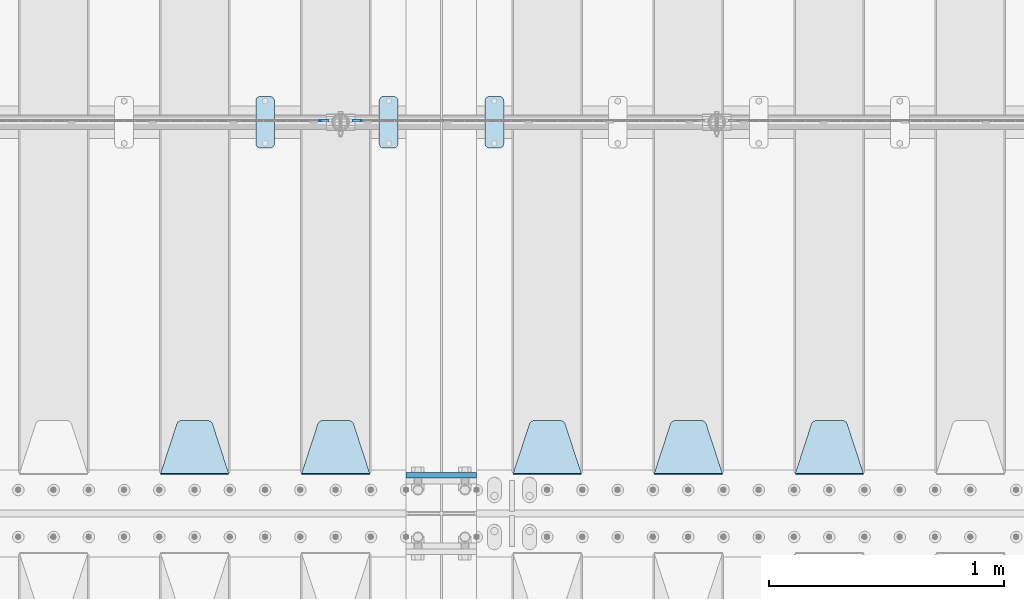
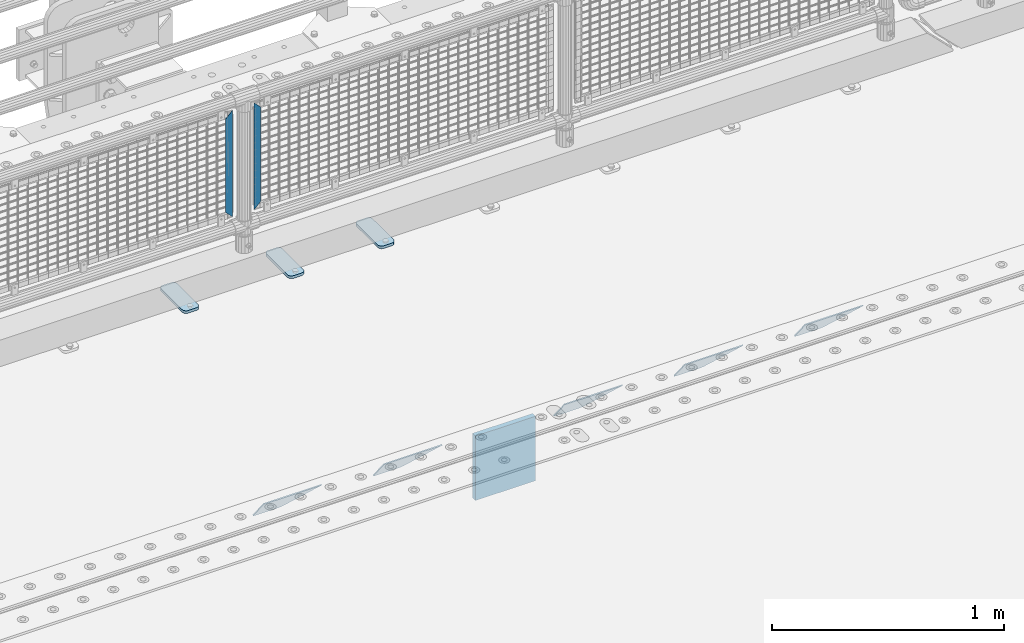
# One storey, part 184 of 208: 11 plates.
"""IFC2X3 building model written with IfcOpenShell, lengths in millimetres."""

import ifcopenshell
import ifcopenshell.guid

model = None  # the IFC model being written
_history = None  # IfcOwnerHistory: only IFC2X3 demands one
_inside = {}  # id of a spatial element -> (the spatial element, [elements in it])
_under = {}  # id of a project, library or spatial element -> (it, [spatial elements below it])
_declared = {}  # id of a project -> (the project, [libraries it declares])
_typed = {}  # id of a type object -> (the type object, [elements of that type])
_made_of = {}  # id of a material, layer set ... -> (it, [elements and type objects made of it])


def new_model(schema):
    """Start an empty IFC model of exactly this schema.

    Asked for "IFC4X3", IfcOpenShell would pick the latest addendum, in which some entities
    have other attributes; the version numbers below select the first issue.
    IFC2X3 requires an IfcOwnerHistory on every rooted entity: one is made here for all.
    """
    global model, _history
    if schema == "IFC4X3":
        model = ifcopenshell.file(schema_version=(4, 3, 0, 0))
    else:
        model = ifcopenshell.file(schema=schema)
    _inside.clear()
    _under.clear()
    _declared.clear()
    _typed.clear()
    _made_of.clear()
    _history = None
    if model.schema == "IFC2X3":
        org = make("IfcOrganization", Name="unknown")
        user = make(
            "IfcPersonAndOrganization",
            ThePerson=make("IfcPerson", FamilyName="unknown"),
            TheOrganization=org,
        )
        app = make(
            "IfcApplication",
            ApplicationDeveloper=org,
            Version="unknown",
            ApplicationFullName="unknown",
            ApplicationIdentifier="unknown",
        )
        _history = make(
            "IfcOwnerHistory",
            OwningUser=user,
            OwningApplication=app,
            ChangeAction="ADDED",
            CreationDate=0,
        )
    return model


def make(cls, **values):
    """One entity of the class cls with the attributes given. An attribute that is None is left unset."""
    return model.create_entity(
        cls, **{name: value for name, value in values.items() if value is not None}
    )


def rooted(cls, **values):
    """An entity with a GlobalId (a new one), such as an element, a storey or a relation."""
    return make(cls, GlobalId=ifcopenshell.guid.new(), OwnerHistory=_history, **values)


def si_unit(unit_type, name, prefix=None):
    """IfcSIUnit, for example si_unit("LENGTHUNIT", "METRE", prefix="MILLI")."""
    return make("IfcSIUnit", UnitType=unit_type, Prefix=prefix, Name=name)


def assignment(units):
    """IfcUnitAssignment: the units of a project."""
    return None if units is None else make("IfcUnitAssignment", Units=units)


def point(xyz):
    """IfcCartesianPoint."""
    return None if xyz is None else make("IfcCartesianPoint", Coordinates=xyz)


def direction(xyz):
    """IfcDirection."""
    return None if xyz is None else make("IfcDirection", DirectionRatios=xyz)


def frame(location, z_axis=None, x_axis=None):
    """IfcAxis2Placement3D, a coordinate frame: its origin and axes. An axis left out is left unset."""
    return make(
        "IfcAxis2Placement3D",
        Location=point(location),
        Axis=direction(z_axis),
        RefDirection=direction(x_axis),
    )


def origin_with_axes():
    """The frame at (0, 0, 0) with the z axis (0, 0, 1) and the x axis (1, 0, 0) written out."""
    return frame((0.0, 0.0, 0.0), z_axis=(0.0, 0.0, 1.0), x_axis=(1.0, 0.0, 0.0))


def place(relative_to, where):
    """IfcLocalPlacement: puts the frame where relative to a parent placement (None: the world)."""
    return make(
        "IfcLocalPlacement", PlacementRelTo=relative_to, RelativePlacement=where
    )


def context(
    kind, dimensions, precision=None, world=None, true_north=None, identifier=None
):
    """IfcGeometricRepresentationContext, for example the 3D "Model" context."""
    return make(
        "IfcGeometricRepresentationContext",
        ContextIdentifier=identifier,
        ContextType=kind,
        CoordinateSpaceDimension=dimensions,
        Precision=precision,
        WorldCoordinateSystem=world,
        TrueNorth=true_north,
    )


def subcontext(parent, identifier, kind, view, scale=None):
    """IfcGeometricRepresentationSubContext, for example "Body" below "Model"."""
    return make(
        "IfcGeometricRepresentationSubContext",
        ContextIdentifier=identifier,
        ContextType=kind,
        ParentContext=parent,
        TargetScale=scale,
        TargetView=view,
    )


def project(units=None, contexts=None):
    """IfcProject with its units and contexts."""
    return rooted(
        "IfcProject",
        Name="project",
        RepresentationContexts=contexts,
        UnitsInContext=assignment(units),
    )


def spatial(cls, under=None, at=None, **own):
    """A site, building, storey or space (cls), placed at a placement, below another one or the project."""
    s = rooted(cls, ObjectPlacement=at, **own)
    if under is not None:
        _under.setdefault(under.id(), (under, []))[1].append(s)
    return s


def faces_of(points, faces, orient=None, outer=None):
    """IfcFace entities. A face is a list of loops; a loop is a list of indices into points, from 0.

    orient and outer hold one flag for each loop. By default every Orientation is true, the
    first loop of a face is its IfcFaceOuterBound and the others are IfcFaceBound.
    """
    made = []
    for i, loops in enumerate(faces):
        bounds = []
        for j, loop in enumerate(loops):
            is_outer = j == 0 if outer is None else outer[i][j]
            bounds.append(
                make(
                    "IfcFaceOuterBound" if is_outer else "IfcFaceBound",
                    Bound=make("IfcPolyLoop", Polygon=[points[k] for k in loop]),
                    Orientation=True if orient is None else orient[i][j],
                )
            )
        made.append(make("IfcFace", Bounds=bounds))
    return made


def faceted_brep(points, faces, orient=None, outer=None, voids=None):
    """IfcFacetedBrep: a solid bounded by flat faces; with voids (closed shells), ...WithVoids."""
    shared = [point(p) for p in points]
    hull = make("IfcClosedShell", CfsFaces=faces_of(shared, faces, orient, outer))
    if voids is None:
        return make("IfcFacetedBrep", Outer=hull)
    return make(
        "IfcFacetedBrepWithVoids",
        Outer=hull,
        Voids=[
            make(cls, CfsFaces=faces_of(shared, fs, o, b)) for cls, fs, o, b in voids
        ],
    )


def shape(context_of_items, identifier, shape_type, items):
    """IfcShapeRepresentation: the items that make up one representation, for example the "Body"."""
    return make(
        "IfcShapeRepresentation",
        ContextOfItems=context_of_items,
        RepresentationIdentifier=identifier,
        RepresentationType=shape_type,
        Items=items,
    )


def material(Name=None, Category=None):
    """IfcMaterial."""
    return make("IfcMaterial", Name=Name, Category=Category)


def made_of(thing, what):
    """Note that an element or type object is made of a material, layer set ...; save() writes the relation."""
    if what is not None:
        _made_of.setdefault(what.id(), (what, []))[1].append(thing)
    return thing


def type_object(cls, material=None, **own):
    """A type object (cls), such as IfcWallType, which elements share."""
    return made_of(rooted(cls, **own), material)


def element(
    cls,
    number,
    at=None,
    inside=None,
    cuts=None,
    type_object=None,
    material=None,
    context=None,
    identifier="Body",
    shape_type=None,
    held_by="IfcProductDefinitionShape",
    body=None,
    shapes=None,
    **own,
):
    """One element of the class cls, such as IfcWall. Its Tag is "e" and its number.

    at: its placement. inside: the storey or other place that contains it. cuts: it is an
    opening in that element (IfcRelVoidsElement). A single representation is given by context,
    identifier, shape_type and body (its items); several are given by shapes. held_by: the class
    of the entity that holds the representations. save() writes the other relations.
    """
    e = rooted(cls, Tag="e%d" % number, ObjectPlacement=at, **own)
    if body is not None:
        shapes = [shape(context, identifier, shape_type, body)]
    if shapes is not None:
        e.Representation = make(held_by, Representations=shapes)
    if inside is not None:
        _inside.setdefault(inside.id(), (inside, []))[1].append(e)
    if cuts is not None:
        rooted(
            "IfcRelVoidsElement", RelatingBuildingElement=cuts, RelatedOpeningElement=e
        )
    if type_object is not None:
        _typed.setdefault(type_object.id(), (type_object, []))[1].append(e)
    return made_of(e, material)


def aggregate(whole, parts):
    """IfcRelAggregates: a whole, such as a stair, and the parts it consists of."""
    return rooted("IfcRelAggregates", RelatingObject=whole, RelatedObjects=parts)


def save(model, path):
    """Write the relations noted so far, then the file.

    IfcRelAggregates (storeys below a building ...), IfcRelContainedInSpatialStructure (elements
    in a storey), IfcRelDefinesByType, IfcRelAssociatesMaterial and IfcRelDeclares: one each for
    every whole, place, type object, material and project.
    """
    for whole, parts in _under.values():
        aggregate(whole, parts)
    for where, things in _inside.values():
        rooted(
            "IfcRelContainedInSpatialStructure",
            RelatedElements=things,
            RelatingStructure=where,
        )
    for kind, things in _typed.values():
        rooted("IfcRelDefinesByType", RelatedObjects=things, RelatingType=kind)
    for what, things in _made_of.values():
        rooted("IfcRelAssociatesMaterial", RelatedObjects=things, RelatingMaterial=what)
    for by, libraries in _declared.values():
        rooted("IfcRelDeclares", RelatingContext=by, RelatedDefinitions=libraries)
    model.write(path)


model = new_model("IFC2X3")

# Units and contexts
model_context = context("Model", 3, precision=1e-05, world=origin_with_axes())
body_context = subcontext(model_context, "Body", "Model", "MODEL_VIEW")
ifc_project = project(units=[si_unit("LENGTHUNIT", "METRE", prefix="MILLI"), si_unit("AREAUNIT", "SQUARE_METRE"), si_unit("VOLUMEUNIT", "CUBIC_METRE"), si_unit("MASSUNIT", "GRAM", prefix="KILO"), si_unit("TIMEUNIT", "SECOND"), si_unit("PLANEANGLEUNIT", "RADIAN"), si_unit("SOLIDANGLEUNIT", "STERADIAN"), si_unit("THERMODYNAMICTEMPERATUREUNIT", "DEGREE_CELSIUS"), si_unit("LUMINOUSINTENSITYUNIT", "LUMEN")], contexts=[model_context])

# Site, building, storey
site_placement = place(None, origin_with_axes())
site = spatial("IfcSite", under=ifc_project, at=site_placement, CompositionType="ELEMENT")
building_placement = place(site_placement, origin_with_axes())
building = spatial("IfcBuilding", under=site, at=building_placement, Name="Standard", CompositionType="ELEMENT")
storey_placement = place(building_placement, origin_with_axes())
storey = spatial("IfcBuildingStorey", under=building, at=storey_placement, Name="Undefined", CompositionType="ELEMENT", Elevation=0.0)

# Plates
ifc_material_1 = material(Name="STEEL/S355N")
plate_type_1 = type_object("IfcPlateType", PredefinedType="NOTDEFINED")
plate_1_placement = place(storey_placement, frame((-30350.0, 3162.5, -340.000000000044), z_axis=(0.0, 0.0, 1.0), x_axis=(1.0, 0.0, 0.0)))
element("IfcPlate", 1, at=plate_1_placement, inside=storey, type_object=plate_type_1, material=ifc_material_1, context=body_context, shape_type="Brep", body=[
    faceted_brep([(0.0, -12.5, 0.0), (0.0, -12.5, 340.0), (0.0, 12.5, 340.0), (0.0, 12.5, 0.0), (300.0, -12.5, 340.0), (300.0, 12.5, 340.0), (300.0, -12.5, 0.0), (300.0, 12.5, 0.0)], [[[0, 1, 2, 3]], [[1, 4, 5, 2]], [[4, 6, 7, 5]], [[6, 0, 3, 7]], [[5, 7, 3, 2]], [[6, 4, 1, 0]]]),
])
ifc_material_2 = material(Name="STEEL/S355J2")
plate_type_2 = type_object("IfcPlateType", PredefinedType="NOTDEFINED")
plate_2_placement = place(storey_placement, frame((-30465.0, 4774.5, 21.0199999999977), z_axis=(1.0, 0.0, 0.0), x_axis=(0.0, -1.0, 0.0)))
element("IfcPlate", 2, at=plate_2_placement, inside=storey, type_object=plate_type_2, material=ifc_material_2, context=body_context, shape_type="Brep", body=[
    faceted_brep([(0.0, -7.0, 20.0), (0.0, -7.0, 60.0), (0.0, 7.0, 60.0), (0.0, 7.0, 20.0), (0.384294391935327, -7.0, 63.9018064403208), (0.384294391935327, 7.0, 63.9018064403208), (1.52240934977453, -7.0, 67.6536686473009), (1.52240934977453, 7.0, 67.6536686473009), (3.37060775394912, -7.0, 71.1114046603907), (3.37060775394912, 7.0, 71.1114046603907), (5.85786437626939, -7.0, 74.1421356237297), (5.85786437626939, 7.0, 74.1421356237297), (8.8885953396084, -7.0, 76.62939224605), (8.8885953396084, 7.0, 76.62939224605), (12.3463313526981, -7.0, 78.4775906502255), (12.3463313526981, 7.0, 78.4775906502255), (16.0981935596774, -7.0, 79.6157056080629), (16.0981935596774, 7.0, 79.6157056080629), (20.0, -7.0, 80.0), (20.0, 7.0, 80.0), (200.0, -7.0, 80.0), (200.0, 7.0, 80.0), (203.901806440323, -7.0, 79.6157056080629), (203.901806440323, 7.0, 79.6157056080629), (207.653668647302, -7.0, 78.4775906502255), (207.653668647302, 7.0, 78.4775906502255), (211.111404660393, -7.0, 76.62939224605), (211.111404660393, 7.0, 76.62939224605), (214.142135623731, -7.0, 74.1421356237297), (214.142135623731, 7.0, 74.1421356237297), (216.629392246051, -7.0, 71.1114046603907), (216.629392246051, 7.0, 71.1114046603907), (218.477590650225, -7.0, 67.6536686473009), (218.477590650225, 7.0, 67.6536686473009), (219.615705608065, -7.0, 63.9018064403208), (219.615705608065, 7.0, 63.9018064403208), (220.0, -7.0, 60.0), (220.0, 7.0, 60.0), (220.0, -7.0, 20.0), (220.0, 7.0, 20.0), (219.615705608065, -7.0, 16.0981935596792), (219.615705608065, 7.0, 16.0981935596792), (218.477590650225, -7.0, 12.3463313526991), (218.477590650225, 7.0, 12.3463313526991), (216.629392246051, -7.0, 8.88859533960931), (216.629392246051, 7.0, 8.88859533960931), (214.142135623731, -7.0, 5.8578643762703), (214.142135623731, 7.0, 5.8578643762703), (211.111404660393, -7.0, 3.37060775395003), (211.111404660393, 7.0, 3.37060775395003), (207.653668647302, -7.0, 1.52240934977453), (207.653668647302, 7.0, 1.52240934977453), (203.901806440323, -7.0, 0.384294391937146), (203.901806440323, 7.0, 0.384294391937146), (200.0, -7.0, 0.0), (200.0, 7.0, 0.0), (20.0, -7.0, 0.0), (20.0, 7.0, 0.0), (16.0981935596774, -7.0, 0.384294391937146), (16.0981935596774, 7.0, 0.384294391937146), (12.3463313526981, -7.0, 1.52240934977453), (12.3463313526981, 7.0, 1.52240934977453), (8.8885953396084, -7.0, 3.37060775395003), (8.8885953396084, 7.0, 3.37060775395003), (5.85786437626939, -7.0, 5.8578643762703), (5.85786437626939, 7.0, 5.8578643762703), (3.37060775394912, -7.0, 8.88859533960931), (3.37060775394912, 7.0, 8.88859533960931), (1.52240934977453, -7.0, 12.3463313526991), (1.52240934977453, 7.0, 12.3463313526991), (0.384294391935327, -7.0, 16.0981935596792), (0.384294391935327, 7.0, 16.0981935596792)], [[[0, 1, 2, 3]], [[1, 4, 5, 2]], [[4, 6, 7, 5]], [[6, 8, 9, 7]], [[8, 10, 11, 9]], [[10, 12, 13, 11]], [[12, 14, 15, 13]], [[14, 16, 17, 15]], [[16, 18, 19, 17]], [[18, 20, 21, 19]], [[20, 22, 23, 21]], [[22, 24, 25, 23]], [[24, 26, 27, 25]], [[26, 28, 29, 27]], [[28, 30, 31, 29]], [[30, 32, 33, 31]], [[32, 34, 35, 33]], [[34, 36, 37, 35]], [[36, 38, 39, 37]], [[38, 40, 41, 39]], [[40, 42, 43, 41]], [[42, 44, 45, 43]], [[44, 46, 47, 45]], [[46, 48, 49, 47]], [[48, 50, 51, 49]], [[50, 52, 53, 51]], [[52, 54, 55, 53]], [[54, 56, 57, 55]], [[56, 58, 59, 57]], [[58, 60, 61, 59]], [[60, 62, 63, 61]], [[62, 64, 65, 63]], [[64, 66, 67, 65]], [[66, 68, 69, 67]], [[68, 70, 71, 69]], [[70, 0, 3, 71]], [[5, 7, 9, 11, 13, 15, 17, 19, 21, 23, 25, 27, 29, 31, 33, 35, 37, 39, 41, 43, 45, 47, 49, 51, 53, 55, 57, 59, 61, 63, 65, 67, 69, 71, 3, 2]], [[70, 68, 66, 64, 62, 60, 58, 56, 54, 52, 50, 48, 46, 44, 42, 40, 38, 36, 34, 32, 30, 28, 26, 24, 22, 20, 18, 16, 14, 12, 10, 8, 6, 4, 1, 0]]]),
])
plate_3_placement = place(storey_placement, frame((-30990.0, 4774.5, 21.0199999999977), z_axis=(1.0, 0.0, 0.0), x_axis=(0.0, -1.0, 0.0)))
element("IfcPlate", 3, at=plate_3_placement, inside=storey, type_object=plate_type_2, material=ifc_material_2, context=body_context, shape_type="Brep", body=[
    faceted_brep([(0.0, -7.0, 20.0), (0.0, -7.0, 60.0), (0.0, 7.0, 60.0), (0.0, 7.0, 20.0), (0.384294391935327, -7.0, 63.9018064403208), (0.384294391935327, 7.0, 63.9018064403208), (1.52240934977453, -7.0, 67.6536686473009), (1.52240934977453, 7.0, 67.6536686473009), (3.37060775394912, -7.0, 71.1114046603907), (3.37060775394912, 7.0, 71.1114046603907), (5.85786437626939, -7.0, 74.1421356237297), (5.85786437626939, 7.0, 74.1421356237297), (8.8885953396084, -7.0, 76.62939224605), (8.8885953396084, 7.0, 76.62939224605), (12.3463313526981, -7.0, 78.4775906502255), (12.3463313526981, 7.0, 78.4775906502255), (16.0981935596774, -7.0, 79.6157056080629), (16.0981935596774, 7.0, 79.6157056080629), (20.0, -7.0, 80.0), (20.0, 7.0, 80.0), (200.0, -7.0, 80.0), (200.0, 7.0, 80.0), (203.901806440323, -7.0, 79.6157056080629), (203.901806440323, 7.0, 79.6157056080629), (207.653668647302, -7.0, 78.4775906502255), (207.653668647302, 7.0, 78.4775906502255), (211.111404660393, -7.0, 76.62939224605), (211.111404660393, 7.0, 76.62939224605), (214.142135623731, -7.0, 74.1421356237297), (214.142135623731, 7.0, 74.1421356237297), (216.629392246051, -7.0, 71.1114046603907), (216.629392246051, 7.0, 71.1114046603907), (218.477590650225, -7.0, 67.6536686473009), (218.477590650225, 7.0, 67.6536686473009), (219.615705608065, -7.0, 63.9018064403208), (219.615705608065, 7.0, 63.9018064403208), (220.0, -7.0, 60.0), (220.0, 7.0, 60.0), (220.0, -7.0, 20.0), (220.0, 7.0, 20.0), (219.615705608065, -7.0, 16.0981935596792), (219.615705608065, 7.0, 16.0981935596792), (218.477590650225, -7.0, 12.3463313526991), (218.477590650225, 7.0, 12.3463313526991), (216.629392246051, -7.0, 8.88859533960931), (216.629392246051, 7.0, 8.88859533960931), (214.142135623731, -7.0, 5.8578643762703), (214.142135623731, 7.0, 5.8578643762703), (211.111404660393, -7.0, 3.37060775395003), (211.111404660393, 7.0, 3.37060775395003), (207.653668647302, -7.0, 1.52240934977453), (207.653668647302, 7.0, 1.52240934977453), (203.901806440323, -7.0, 0.384294391937146), (203.901806440323, 7.0, 0.384294391937146), (200.0, -7.0, 0.0), (200.0, 7.0, 0.0), (20.0, -7.0, 0.0), (20.0, 7.0, 0.0), (16.0981935596774, -7.0, 0.384294391937146), (16.0981935596774, 7.0, 0.384294391937146), (12.3463313526981, -7.0, 1.52240934977453), (12.3463313526981, 7.0, 1.52240934977453), (8.8885953396084, -7.0, 3.37060775395003), (8.8885953396084, 7.0, 3.37060775395003), (5.85786437626939, -7.0, 5.8578643762703), (5.85786437626939, 7.0, 5.8578643762703), (3.37060775394912, -7.0, 8.88859533960931), (3.37060775394912, 7.0, 8.88859533960931), (1.52240934977453, -7.0, 12.3463313526991), (1.52240934977453, 7.0, 12.3463313526991), (0.384294391935327, -7.0, 16.0981935596792), (0.384294391935327, 7.0, 16.0981935596792)], [[[0, 1, 2, 3]], [[1, 4, 5, 2]], [[4, 6, 7, 5]], [[6, 8, 9, 7]], [[8, 10, 11, 9]], [[10, 12, 13, 11]], [[12, 14, 15, 13]], [[14, 16, 17, 15]], [[16, 18, 19, 17]], [[18, 20, 21, 19]], [[20, 22, 23, 21]], [[22, 24, 25, 23]], [[24, 26, 27, 25]], [[26, 28, 29, 27]], [[28, 30, 31, 29]], [[30, 32, 33, 31]], [[32, 34, 35, 33]], [[34, 36, 37, 35]], [[36, 38, 39, 37]], [[38, 40, 41, 39]], [[40, 42, 43, 41]], [[42, 44, 45, 43]], [[44, 46, 47, 45]], [[46, 48, 49, 47]], [[48, 50, 51, 49]], [[50, 52, 53, 51]], [[52, 54, 55, 53]], [[54, 56, 57, 55]], [[56, 58, 59, 57]], [[58, 60, 61, 59]], [[60, 62, 63, 61]], [[62, 64, 65, 63]], [[64, 66, 67, 65]], [[66, 68, 69, 67]], [[68, 70, 71, 69]], [[70, 0, 3, 71]], [[5, 7, 9, 11, 13, 15, 17, 19, 21, 23, 25, 27, 29, 31, 33, 35, 37, 39, 41, 43, 45, 47, 49, 51, 53, 55, 57, 59, 61, 63, 65, 67, 69, 71, 3, 2]], [[70, 68, 66, 64, 62, 60, 58, 56, 54, 52, 50, 48, 46, 44, 42, 40, 38, 36, 34, 32, 30, 28, 26, 24, 22, 20, 18, 16, 14, 12, 10, 8, 6, 4, 1, 0]]]),
])
plate_4_placement = place(storey_placement, frame((-30015.0, 4774.5, 21.0199999999977), z_axis=(1.0, 0.0, 0.0), x_axis=(0.0, -1.0, 0.0)))
element("IfcPlate", 4, at=plate_4_placement, inside=storey, type_object=plate_type_2, material=ifc_material_2, context=body_context, shape_type="Brep", body=[
    faceted_brep([(0.0, -7.0, 20.0), (0.0, -7.0, 60.0), (0.0, 7.0, 60.0), (0.0, 7.0, 20.0), (0.384294391935327, -7.0, 63.9018064403208), (0.384294391935327, 7.0, 63.9018064403208), (1.52240934977453, -7.0, 67.6536686473009), (1.52240934977453, 7.0, 67.6536686473009), (3.37060775394912, -7.0, 71.1114046603907), (3.37060775394912, 7.0, 71.1114046603907), (5.85786437626939, -7.0, 74.1421356237297), (5.85786437626939, 7.0, 74.1421356237297), (8.8885953396084, -7.0, 76.62939224605), (8.8885953396084, 7.0, 76.62939224605), (12.3463313526981, -7.0, 78.4775906502255), (12.3463313526981, 7.0, 78.4775906502255), (16.0981935596774, -7.0, 79.6157056080629), (16.0981935596774, 7.0, 79.6157056080629), (20.0, -7.0, 80.0), (20.0, 7.0, 80.0), (200.0, -7.0, 80.0), (200.0, 7.0, 80.0), (203.901806440323, -7.0, 79.6157056080629), (203.901806440323, 7.0, 79.6157056080629), (207.653668647302, -7.0, 78.4775906502255), (207.653668647302, 7.0, 78.4775906502255), (211.111404660393, -7.0, 76.62939224605), (211.111404660393, 7.0, 76.62939224605), (214.142135623731, -7.0, 74.1421356237297), (214.142135623731, 7.0, 74.1421356237297), (216.629392246051, -7.0, 71.1114046603907), (216.629392246051, 7.0, 71.1114046603907), (218.477590650225, -7.0, 67.6536686473009), (218.477590650225, 7.0, 67.6536686473009), (219.615705608065, -7.0, 63.9018064403208), (219.615705608065, 7.0, 63.9018064403208), (220.0, -7.0, 60.0), (220.0, 7.0, 60.0), (220.0, -7.0, 20.0), (220.0, 7.0, 20.0), (219.615705608065, -7.0, 16.0981935596792), (219.615705608065, 7.0, 16.0981935596792), (218.477590650225, -7.0, 12.3463313526991), (218.477590650225, 7.0, 12.3463313526991), (216.629392246051, -7.0, 8.88859533960931), (216.629392246051, 7.0, 8.88859533960931), (214.142135623731, -7.0, 5.8578643762703), (214.142135623731, 7.0, 5.8578643762703), (211.111404660393, -7.0, 3.37060775395003), (211.111404660393, 7.0, 3.37060775395003), (207.653668647302, -7.0, 1.52240934977453), (207.653668647302, 7.0, 1.52240934977453), (203.901806440323, -7.0, 0.384294391937146), (203.901806440323, 7.0, 0.384294391937146), (200.0, -7.0, 0.0), (200.0, 7.0, 0.0), (20.0, -7.0, 0.0), (20.0, 7.0, 0.0), (16.0981935596774, -7.0, 0.384294391937146), (16.0981935596774, 7.0, 0.384294391937146), (12.3463313526981, -7.0, 1.52240934977453), (12.3463313526981, 7.0, 1.52240934977453), (8.8885953396084, -7.0, 3.37060775395003), (8.8885953396084, 7.0, 3.37060775395003), (5.85786437626939, -7.0, 5.8578643762703), (5.85786437626939, 7.0, 5.8578643762703), (3.37060775394912, -7.0, 8.88859533960931), (3.37060775394912, 7.0, 8.88859533960931), (1.52240934977453, -7.0, 12.3463313526991), (1.52240934977453, 7.0, 12.3463313526991), (0.384294391935327, -7.0, 16.0981935596792), (0.384294391935327, 7.0, 16.0981935596792)], [[[0, 1, 2, 3]], [[1, 4, 5, 2]], [[4, 6, 7, 5]], [[6, 8, 9, 7]], [[8, 10, 11, 9]], [[10, 12, 13, 11]], [[12, 14, 15, 13]], [[14, 16, 17, 15]], [[16, 18, 19, 17]], [[18, 20, 21, 19]], [[20, 22, 23, 21]], [[22, 24, 25, 23]], [[24, 26, 27, 25]], [[26, 28, 29, 27]], [[28, 30, 31, 29]], [[30, 32, 33, 31]], [[32, 34, 35, 33]], [[34, 36, 37, 35]], [[36, 38, 39, 37]], [[38, 40, 41, 39]], [[40, 42, 43, 41]], [[42, 44, 45, 43]], [[44, 46, 47, 45]], [[46, 48, 49, 47]], [[48, 50, 51, 49]], [[50, 52, 53, 51]], [[52, 54, 55, 53]], [[54, 56, 57, 55]], [[56, 58, 59, 57]], [[58, 60, 61, 59]], [[60, 62, 63, 61]], [[62, 64, 65, 63]], [[64, 66, 67, 65]], [[66, 68, 69, 67]], [[68, 70, 71, 69]], [[70, 0, 3, 71]], [[5, 7, 9, 11, 13, 15, 17, 19, 21, 23, 25, 27, 29, 31, 33, 35, 37, 39, 41, 43, 45, 47, 49, 51, 53, 55, 57, 59, 61, 63, 65, 67, 69, 71, 3, 2]], [[70, 68, 66, 64, 62, 60, 58, 56, 54, 52, 50, 48, 46, 44, 42, 40, 38, 36, 34, 32, 30, 28, 26, 24, 22, 20, 18, 16, 14, 12, 10, 8, 6, 4, 1, 0]]]),
])
plate_type_3 = type_object("IfcPlateType", PredefinedType="NOTDEFINED")
plate_5_placement = place(storey_placement, frame((-28405.0, 3168.23223304702, -1.76776695296758), z_axis=(0.0, 0.707106781186547, -0.707106781186548), x_axis=(-1.0, 0.0, 0.0)))
element("IfcPlate", 5, at=plate_5_placement, inside=storey, type_object=plate_type_3, material=ifc_material_1, context=body_context, shape_type="Brep", body=[
    faceted_brep([(0.0, -2.5, 0.0), (69.345504679477, -2.5, 300.17173142483), (69.345504679477, 2.5, 300.17173142483), (0.0, 2.5, 0.0), (70.9274061199576, -2.5, 304.897442415399), (70.9274061199576, 2.5, 304.8974424154), (73.3818627772307, -2.5, 309.234538108527), (73.3818627772307, 2.5, 309.234538108527), (76.6187032999551, -2.5, 313.023683126103), (76.6187032999551, 2.5, 313.023683126103), (80.5190132704993, -2.5, 316.125672595371), (80.5190132704993, 2.5, 316.125672595371), (84.9395038596849, -2.5, 318.426546230476), (84.9395038596849, 2.50000000000091, 318.426546230476), (89.7177759439219, -2.5, 319.841774983275), (89.7177759439219, 2.50000000000091, 319.841774983275), (94.678286292652, -2.49999999999909, 320.319366455078), (94.678286292652, 2.5, 320.319366455078), (195.321713707348, -2.49999999999909, 320.319366455078), (195.321713707348, 2.5, 320.319366455078), (200.282224056078, -2.5, 319.841774983275), (200.282224056078, 2.5, 319.841774983274), (205.060496140315, -2.5, 318.426546230475), (205.060496140315, 2.5, 318.426546230475), (209.480986729501, -2.5, 316.125672595371), (209.480986729501, 2.50000000000091, 316.125672595371), (213.381296700045, -2.5, 313.023683126102), (213.381296700045, 2.5, 313.023683126102), (216.618137222769, -2.5, 309.234538108526), (216.618137222769, 2.5, 309.234538108527), (219.072593880042, -2.5, 304.897442415399), (219.072593880042, 2.5, 304.897442415399), (220.654495320523, -2.5, 300.17173142483), (220.654495320523, 2.5, 300.17173142483), (290.0, -2.5, 0.0), (290.0, 2.5, 0.0)], [[[0, 1, 2, 3]], [[1, 4, 5, 2]], [[4, 6, 7, 5]], [[6, 8, 9, 7]], [[8, 10, 11, 9]], [[10, 12, 13, 11]], [[12, 14, 15, 13]], [[14, 16, 17, 15]], [[16, 18, 19, 17]], [[18, 20, 21, 19]], [[20, 22, 23, 21]], [[22, 24, 25, 23]], [[24, 26, 27, 25]], [[26, 28, 29, 27]], [[28, 30, 31, 29]], [[30, 32, 33, 31]], [[32, 34, 35, 33]], [[34, 0, 3, 35]], [[5, 7, 9, 11, 13, 15, 17, 19, 21, 23, 25, 27, 29, 31, 33, 35, 3, 2]], [[34, 32, 30, 28, 26, 24, 22, 20, 18, 16, 14, 12, 10, 8, 6, 4, 1, 0]]]),
])
plate_6_placement = place(storey_placement, frame((-29005.0, 3168.23223304702, -1.76776695296758), z_axis=(0.0, 0.707106781186547, -0.707106781186548), x_axis=(-1.0, 0.0, 0.0)))
element("IfcPlate", 6, at=plate_6_placement, inside=storey, type_object=plate_type_3, material=ifc_material_1, context=body_context, shape_type="Brep", body=[
    faceted_brep([(0.0, -2.5, 0.0), (69.345504679477, -2.5, 300.17173142483), (69.345504679477, 2.5, 300.17173142483), (0.0, 2.5, 0.0), (70.9274061199576, -2.5, 304.897442415399), (70.9274061199576, 2.5, 304.8974424154), (73.3818627772307, -2.5, 309.234538108527), (73.3818627772307, 2.5, 309.234538108527), (76.6187032999551, -2.5, 313.023683126103), (76.6187032999551, 2.5, 313.023683126103), (80.5190132704993, -2.5, 316.125672595371), (80.5190132704993, 2.5, 316.125672595371), (84.9395038596849, -2.5, 318.426546230476), (84.9395038596849, 2.50000000000091, 318.426546230476), (89.7177759439219, -2.5, 319.841774983275), (89.7177759439219, 2.50000000000091, 319.841774983275), (94.678286292652, -2.49999999999909, 320.319366455078), (94.678286292652, 2.5, 320.319366455078), (195.321713707348, -2.49999999999909, 320.319366455078), (195.321713707348, 2.5, 320.319366455078), (200.282224056078, -2.5, 319.841774983275), (200.282224056078, 2.5, 319.841774983274), (205.060496140315, -2.5, 318.426546230475), (205.060496140315, 2.5, 318.426546230475), (209.480986729501, -2.5, 316.125672595371), (209.480986729501, 2.50000000000091, 316.125672595371), (213.381296700045, -2.5, 313.023683126102), (213.381296700045, 2.5, 313.023683126102), (216.618137222769, -2.5, 309.234538108526), (216.618137222769, 2.5, 309.234538108527), (219.072593880042, -2.5, 304.897442415399), (219.072593880042, 2.5, 304.897442415399), (220.654495320523, -2.5, 300.17173142483), (220.654495320523, 2.5, 300.17173142483), (290.0, -2.5, 0.0), (290.0, 2.5, 0.0)], [[[0, 1, 2, 3]], [[1, 4, 5, 2]], [[4, 6, 7, 5]], [[6, 8, 9, 7]], [[8, 10, 11, 9]], [[10, 12, 13, 11]], [[12, 14, 15, 13]], [[14, 16, 17, 15]], [[16, 18, 19, 17]], [[18, 20, 21, 19]], [[20, 22, 23, 21]], [[22, 24, 25, 23]], [[24, 26, 27, 25]], [[26, 28, 29, 27]], [[28, 30, 31, 29]], [[30, 32, 33, 31]], [[32, 34, 35, 33]], [[34, 0, 3, 35]], [[5, 7, 9, 11, 13, 15, 17, 19, 21, 23, 25, 27, 29, 31, 33, 35, 3, 2]], [[34, 32, 30, 28, 26, 24, 22, 20, 18, 16, 14, 12, 10, 8, 6, 4, 1, 0]]]),
])
plate_7_placement = place(storey_placement, frame((-29605.0, 3168.23223304702, -1.76776695296758), z_axis=(0.0, 0.707106781186547, -0.707106781186548), x_axis=(-1.0, 0.0, 0.0)))
element("IfcPlate", 7, at=plate_7_placement, inside=storey, type_object=plate_type_3, material=ifc_material_1, context=body_context, shape_type="Brep", body=[
    faceted_brep([(0.0, -2.5, 0.0), (69.345504679477, -2.5, 300.17173142483), (69.345504679477, 2.5, 300.17173142483), (0.0, 2.5, 0.0), (70.9274061199576, -2.5, 304.897442415399), (70.9274061199576, 2.5, 304.8974424154), (73.3818627772307, -2.5, 309.234538108527), (73.3818627772307, 2.5, 309.234538108527), (76.6187032999551, -2.5, 313.023683126103), (76.6187032999551, 2.5, 313.023683126103), (80.5190132704993, -2.5, 316.125672595371), (80.5190132704993, 2.5, 316.125672595371), (84.9395038596849, -2.5, 318.426546230476), (84.9395038596849, 2.50000000000091, 318.426546230476), (89.7177759439219, -2.5, 319.841774983275), (89.7177759439219, 2.50000000000091, 319.841774983275), (94.678286292652, -2.49999999999909, 320.319366455078), (94.678286292652, 2.5, 320.319366455078), (195.321713707348, -2.49999999999909, 320.319366455078), (195.321713707348, 2.5, 320.319366455078), (200.282224056078, -2.5, 319.841774983275), (200.282224056078, 2.5, 319.841774983274), (205.060496140315, -2.5, 318.426546230475), (205.060496140315, 2.5, 318.426546230475), (209.480986729501, -2.5, 316.125672595371), (209.480986729501, 2.50000000000091, 316.125672595371), (213.381296700045, -2.5, 313.023683126102), (213.381296700045, 2.5, 313.023683126102), (216.618137222769, -2.5, 309.234538108526), (216.618137222769, 2.5, 309.234538108527), (219.072593880042, -2.5, 304.897442415399), (219.072593880042, 2.5, 304.897442415399), (220.654495320523, -2.5, 300.17173142483), (220.654495320523, 2.5, 300.17173142483), (290.0, -2.5, 0.0), (290.0, 2.5, 0.0)], [[[0, 1, 2, 3]], [[1, 4, 5, 2]], [[4, 6, 7, 5]], [[6, 8, 9, 7]], [[8, 10, 11, 9]], [[10, 12, 13, 11]], [[12, 14, 15, 13]], [[14, 16, 17, 15]], [[16, 18, 19, 17]], [[18, 20, 21, 19]], [[20, 22, 23, 21]], [[22, 24, 25, 23]], [[24, 26, 27, 25]], [[26, 28, 29, 27]], [[28, 30, 31, 29]], [[30, 32, 33, 31]], [[32, 34, 35, 33]], [[34, 0, 3, 35]], [[5, 7, 9, 11, 13, 15, 17, 19, 21, 23, 25, 27, 29, 31, 33, 35, 3, 2]], [[34, 32, 30, 28, 26, 24, 22, 20, 18, 16, 14, 12, 10, 8, 6, 4, 1, 0]]]),
])
plate_8_placement = place(storey_placement, frame((-30505.0, 3168.23223304702, -1.76776695296758), z_axis=(0.0, 0.707106781186547, -0.707106781186548), x_axis=(-1.0, 0.0, 0.0)))
element("IfcPlate", 8, at=plate_8_placement, inside=storey, type_object=plate_type_3, material=ifc_material_1, context=body_context, shape_type="Brep", body=[
    faceted_brep([(0.0, -2.5, 0.0), (69.345504679477, -2.5, 300.17173142483), (69.345504679477, 2.5, 300.17173142483), (0.0, 2.5, 0.0), (70.9274061199576, -2.5, 304.897442415399), (70.9274061199576, 2.5, 304.8974424154), (73.3818627772307, -2.5, 309.234538108527), (73.3818627772307, 2.5, 309.234538108527), (76.6187032999551, -2.5, 313.023683126103), (76.6187032999551, 2.5, 313.023683126103), (80.5190132704993, -2.5, 316.125672595371), (80.5190132704993, 2.5, 316.125672595371), (84.9395038596849, -2.5, 318.426546230476), (84.9395038596849, 2.50000000000091, 318.426546230476), (89.7177759439219, -2.5, 319.841774983275), (89.7177759439219, 2.50000000000091, 319.841774983275), (94.678286292652, -2.49999999999909, 320.319366455078), (94.678286292652, 2.5, 320.319366455078), (195.321713707348, -2.49999999999909, 320.319366455078), (195.321713707348, 2.5, 320.319366455078), (200.282224056078, -2.5, 319.841774983275), (200.282224056078, 2.5, 319.841774983274), (205.060496140315, -2.5, 318.426546230475), (205.060496140315, 2.5, 318.426546230475), (209.480986729501, -2.5, 316.125672595371), (209.480986729501, 2.50000000000091, 316.125672595371), (213.381296700045, -2.5, 313.023683126102), (213.381296700045, 2.5, 313.023683126102), (216.618137222769, -2.5, 309.234538108526), (216.618137222769, 2.5, 309.234538108527), (219.072593880042, -2.5, 304.897442415399), (219.072593880042, 2.5, 304.897442415399), (220.654495320523, -2.5, 300.17173142483), (220.654495320523, 2.5, 300.17173142483), (290.0, -2.5, 0.0), (290.0, 2.5, 0.0)], [[[0, 1, 2, 3]], [[1, 4, 5, 2]], [[4, 6, 7, 5]], [[6, 8, 9, 7]], [[8, 10, 11, 9]], [[10, 12, 13, 11]], [[12, 14, 15, 13]], [[14, 16, 17, 15]], [[16, 18, 19, 17]], [[18, 20, 21, 19]], [[20, 22, 23, 21]], [[22, 24, 25, 23]], [[24, 26, 27, 25]], [[26, 28, 29, 27]], [[28, 30, 31, 29]], [[30, 32, 33, 31]], [[32, 34, 35, 33]], [[34, 0, 3, 35]], [[5, 7, 9, 11, 13, 15, 17, 19, 21, 23, 25, 27, 29, 31, 33, 35, 3, 2]], [[34, 32, 30, 28, 26, 24, 22, 20, 18, 16, 14, 12, 10, 8, 6, 4, 1, 0]]]),
])
plate_9_placement = place(storey_placement, frame((-31105.0, 3168.23223304702, -1.76776695296758), z_axis=(0.0, 0.707106781186547, -0.707106781186548), x_axis=(-1.0, 0.0, 0.0)))
element("IfcPlate", 9, at=plate_9_placement, inside=storey, type_object=plate_type_3, material=ifc_material_1, context=body_context, shape_type="Brep", body=[
    faceted_brep([(0.0, -2.5, 0.0), (69.345504679477, -2.5, 300.17173142483), (69.345504679477, 2.5, 300.17173142483), (0.0, 2.5, 0.0), (70.9274061199576, -2.5, 304.897442415399), (70.9274061199576, 2.5, 304.8974424154), (73.3818627772307, -2.5, 309.234538108527), (73.3818627772307, 2.5, 309.234538108527), (76.6187032999551, -2.5, 313.023683126103), (76.6187032999551, 2.5, 313.023683126103), (80.5190132704993, -2.5, 316.125672595371), (80.5190132704993, 2.5, 316.125672595371), (84.9395038596849, -2.5, 318.426546230476), (84.9395038596849, 2.50000000000091, 318.426546230476), (89.7177759439219, -2.5, 319.841774983275), (89.7177759439219, 2.50000000000091, 319.841774983275), (94.678286292652, -2.49999999999909, 320.319366455078), (94.678286292652, 2.5, 320.319366455078), (195.321713707348, -2.49999999999909, 320.319366455078), (195.321713707348, 2.5, 320.319366455078), (200.282224056078, -2.5, 319.841774983275), (200.282224056078, 2.5, 319.841774983274), (205.060496140315, -2.5, 318.426546230475), (205.060496140315, 2.5, 318.426546230475), (209.480986729501, -2.5, 316.125672595371), (209.480986729501, 2.50000000000091, 316.125672595371), (213.381296700045, -2.5, 313.023683126102), (213.381296700045, 2.5, 313.023683126102), (216.618137222769, -2.5, 309.234538108526), (216.618137222769, 2.5, 309.234538108527), (219.072593880042, -2.5, 304.897442415399), (219.072593880042, 2.5, 304.897442415399), (220.654495320523, -2.5, 300.17173142483), (220.654495320523, 2.5, 300.17173142483), (290.0, -2.5, 0.0), (290.0, 2.5, 0.0)], [[[0, 1, 2, 3]], [[1, 4, 5, 2]], [[4, 6, 7, 5]], [[6, 8, 9, 7]], [[8, 10, 11, 9]], [[10, 12, 13, 11]], [[12, 14, 15, 13]], [[14, 16, 17, 15]], [[16, 18, 19, 17]], [[18, 20, 21, 19]], [[20, 22, 23, 21]], [[22, 24, 25, 23]], [[24, 26, 27, 25]], [[26, 28, 29, 27]], [[28, 30, 31, 29]], [[30, 32, 33, 31]], [[32, 34, 35, 33]], [[34, 0, 3, 35]], [[5, 7, 9, 11, 13, 15, 17, 19, 21, 23, 25, 27, 29, 31, 33, 35, 3, 2]], [[34, 32, 30, 28, 26, 24, 22, 20, 18, 16, 14, 12, 10, 8, 6, 4, 1, 0]]]),
])
ifc_material_3 = material(Name="Misc_Undefined")
plate_type_4 = type_object("IfcPlateType", PredefinedType="NOTDEFINED")
plate_10_placement = place(storey_placement, frame((-30540.490286459, 4670.5, 879.519963133601), z_axis=(-0.707008801899319, 0.0, -0.707204746899291), x_axis=(-0.70720474689929, 0.0, 0.707008801899319)))
element("IfcPlate", 10, at=plate_10_placement, inside=storey, type_object=plate_type_4, material=ifc_material_3, context=body_context, shape_type="Brep", body=[
    faceted_brep([(0.0, -1.49999999999909, 3.63797880709171e-12), (-348.55218505859, -1.5, 348.655029296875), (-348.55218505859, 1.5, 348.655029296875), (0.0, 1.50000000000182, 3.63797880709171e-12), (-348.544891357418, -1.5, 398.152496337894), (-348.544891357418, 1.5, 398.152496337894), (49.5043945312536, -1.5, 7.6397554948926e-11), (49.5043945312536, 1.5, 7.6397554948926e-11)], [[[0, 1, 2, 3]], [[1, 4, 5, 2]], [[4, 6, 7, 5]], [[6, 0, 3, 7]], [[5, 7, 3, 2]], [[6, 4, 1, 0]]]),
])
plate_11_placement = place(storey_placement, frame((-30717.5003125164, 4670.5, 879.52), z_axis=(0.707103624179499, 0.0, -0.707109938179501), x_axis=(0.707109938179495, 0.0, 0.707103624179505)))
element("IfcPlate", 11, at=plate_11_placement, inside=storey, type_object=plate_type_4, material=ifc_material_3, context=body_context, shape_type="Brep", body=[
    faceted_brep([(0.0, -1.49999999999909, 3.63797880709171e-12), (-348.605163574219, -1.5, 348.602081298821), (-348.605163574219, 1.5, 348.602081298821), (0.0, 1.50000000000182, 3.63797880709171e-12), (-348.605163574219, -1.5, 398.099334716793), (-348.605163574219, 1.5, 398.099334716793), (49.4976959228516, -1.5, 6.91215973347425e-11), (49.4976959228516, 1.5, 6.91215973347425e-11)], [[[0, 1, 2, 3]], [[1, 4, 5, 2]], [[4, 6, 7, 5]], [[6, 0, 3, 7]], [[5, 7, 3, 2]], [[6, 4, 1, 0]]]),
])

save(model, "model.ifc")
